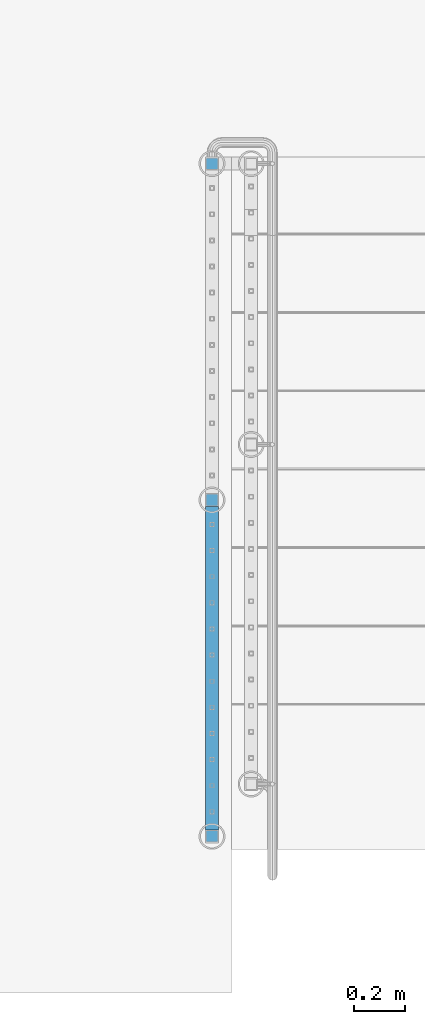
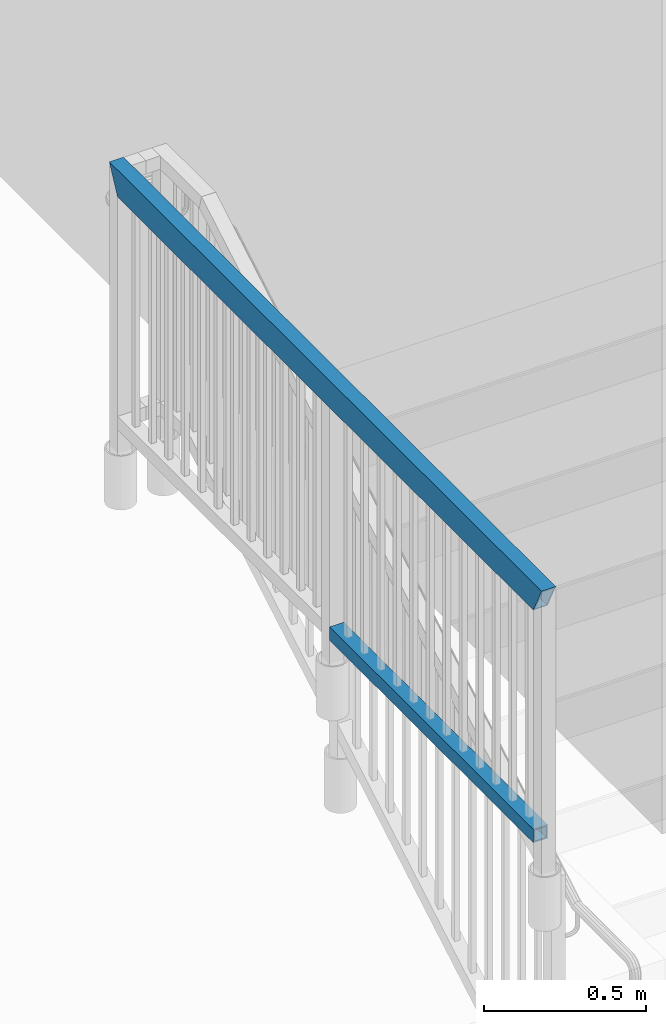
# One storey, part 307 of 975: 2 beams.
"""IFC2X3 building model written with IfcOpenShell, lengths in millimetres."""

from ifc_helpers import new_model, si_unit, frame, origin_with_axes, place, context, subcontext, project, spatial, faceted_brep, material, type_object, element, save


model = new_model("IFC2X3")

# Units and contexts
model_context = context("Model", 3, precision=1e-05, world=origin_with_axes())
body_context = subcontext(model_context, "Body", "Model", "MODEL_VIEW")
ifc_project = project(units=[si_unit("LENGTHUNIT", "METRE", prefix="MILLI"), si_unit("AREAUNIT", "SQUARE_METRE"), si_unit("VOLUMEUNIT", "CUBIC_METRE"), si_unit("MASSUNIT", "GRAM", prefix="KILO"), si_unit("TIMEUNIT", "SECOND"), si_unit("PLANEANGLEUNIT", "RADIAN"), si_unit("SOLIDANGLEUNIT", "STERADIAN"), si_unit("THERMODYNAMICTEMPERATUREUNIT", "DEGREE_CELSIUS"), si_unit("LUMINOUSINTENSITYUNIT", "LUMEN")], contexts=[model_context])

# Site, building, storey
site_placement = place(None, origin_with_axes())
site = spatial("IfcSite", under=ifc_project, at=site_placement, CompositionType="ELEMENT")
building_placement = place(site_placement, origin_with_axes())
building = spatial("IfcBuilding", under=site, at=building_placement, Name="Undefined", CompositionType="ELEMENT")
storey_placement = place(building_placement, origin_with_axes())
storey = spatial("IfcBuildingStorey", under=building, at=storey_placement, Name="Undefined", CompositionType="ELEMENT", Elevation=0.0)

# Beams
ifc_material = material()
beam_type_1 = type_object("IfcBeamType", Name="HSS2X2X.188_TUBES", PredefinedType="NOTDEFINED")
beam_1_placement = place(storey_placement, frame((-3343.27499858123, 609.600352646448, 4229.10002239251), z_axis=(-0.999999999999998, 6.90000001668524e-08, 0.0), x_axis=(0.0, 1.0, 0.0)))
element("IfcBeam", 1, at=beam_1_placement, inside=storey, type_object=beam_type_1, material=ifc_material, Name="HANDRAIL", ObjectType="HSS2X2X.188_TUBES", context=body_context, shape_type="Brep", body=[
    faceted_brep([(25.3999997357314, 20.6374999999898, -20.6374999999998), (25.4000002641624, -20.6375000000153, -20.6374999999998), (1282.70000035021, -20.637500000109, -20.6374999999998), (1282.70000072169, 20.6374999998907, -20.6374999999998), (25.4000002641624, -20.6375000000153, 20.6374999999998), (1282.70000035021, -20.637500000109, 20.6374999999998), (25.3999997357314, 20.6374999999898, 20.6374999999998), (1282.70000072169, 20.6374999998907, 20.6374999999998), (25.4000003077635, 25.3999999999942, -25.3999999999996), (25.3999996747552, 25.3999999999905, 25.3999999999996), (1282.70000076455, 25.3999999998914, 25.4000000000001), (1282.70000076455, 25.3999999998914, -25.4000000000001), (25.4000003251349, -25.4000000000124, 25.3999999999996), (1282.70000030735, -25.4000000001088, 25.4000000000001), (25.4000003077854, -25.4000000000087, -25.3999999999996), (1282.70000030735, -25.4000000001088, -25.4000000000001)], [[[0, 1, 2, 3]], [[1, 4, 5, 2]], [[4, 6, 7, 5]], [[6, 0, 3, 7]], [[8, 9, 10, 11]], [[9, 12, 13, 10]], [[12, 14, 15, 13]], [[14, 8, 11, 15]], [[13, 15, 11, 10], [5, 7, 3, 2]], [[14, 12, 9, 8], [6, 4, 1, 0]]]),
])
beam_type_2 = type_object("IfcBeamType", Name="HSS2X4X.188_TUBES", PredefinedType="NOTDEFINED")
beam_2_placement = place(storey_placement, frame((-3343.27499858123, 609.600351850526, 5130.80000243843), z_axis=(0.0, 0.0, 1.0), x_axis=(0.0, 1.0, 0.0)))
element("IfcBeam", 2, at=beam_2_placement, inside=storey, type_object=beam_type_2, material=ifc_material, Name="HANDRAIL", ObjectType="HSS2X4X.188_TUBES", context=body_context, shape_type="Brep", body=[
    faceted_brep([(23.0187497854322, 20.6374999999998, -46.0374999999976), (23.0187497854322, -20.6374999999998, -46.0374999999976), (2593.18125043954, -20.6374999999998, -46.0374999997803), (2593.18125043954, 20.6374999999998, -46.0374999997803), (-23.0187510838365, -20.6374999999998, 46.0374999999985), (2639.21874957027, -20.6374999999998, 46.0375000002241), (-23.0187510838365, 20.6374999999998, 46.0374999999985), (2639.21874957027, 20.6374999999998, 46.0375000002241), (25.3999998303943, 25.4000000000001, -50.7999999999975), (-25.4000011287986, 25.4000000000001, 50.7999999999984), (2641.59999952531, 25.4000000000001, 50.8000000002239), (2590.8000004845, 25.4000000000001, -50.7999999997801), (-25.4000011287986, -25.4000000000001, 50.7999999999984), (2641.59999952531, -25.4000000000001, 50.8000000002239), (25.3999998303943, -25.4000000000001, -50.7999999999975), (2590.8000004845, -25.4000000000001, -50.7999999997801)], [[[0, 1, 2, 3]], [[1, 4, 5, 2]], [[4, 6, 7, 5]], [[6, 0, 3, 7]], [[8, 9, 10, 11]], [[9, 12, 13, 10]], [[12, 14, 15, 13]], [[14, 8, 11, 15]], [[13, 15, 11, 10], [5, 7, 3, 2]], [[14, 12, 9, 8], [6, 4, 1, 0]]]),
])

save(model, "model.ifc")
